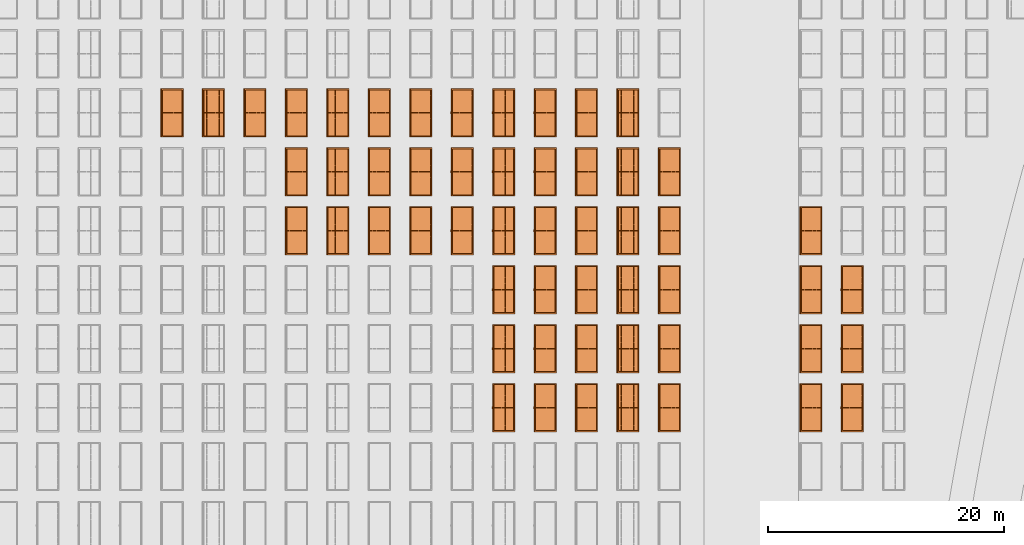
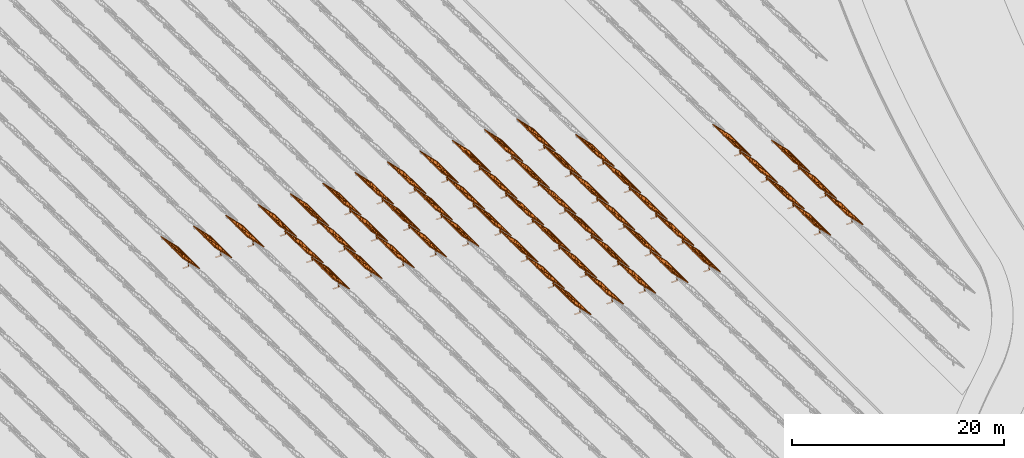
# One storey, part 23 of 39: 54 proxies.
"""IFC2X3 building model written with IfcOpenShell, lengths in millimetres."""

from ifc_helpers import new_model, entity, si_unit, converted_unit, derived_unit, direction, frame, frame_2d, origin, origin_2d_with_axis, place, context, subcontext, project, spatial, polyline, rectangle, outline, extrude, source, transform, mapped, material, material_list, element, save


model = new_model("IFC2X3")

# Units and contexts
model_context = context("Model", 3, precision=1e-06, world=origin(), true_north=direction((2.0, 6.12303176911189e-17, 1.0)))
context_of_model = context(None, 3, precision=1e-06, world=origin(), true_north=direction((2.0, 6.12303176911189e-17, 1.0)))
body_context = subcontext(model_context, "Body", "Model", "MODEL_VIEW")
ifc_project = project(units=[si_unit("LENGTHUNIT", "METRE", prefix="MILLI"), si_unit("AREAUNIT", "SQUARE_METRE", prefix="MILLI"), si_unit("VOLUMEUNIT", "CUBIC_METRE", prefix="MILLI"), converted_unit("PLANEANGLEUNIT", "DEGREE", entity("IfcRatioMeasure", 0.0174532925199433), si_unit("PLANEANGLEUNIT", "RADIAN"), dimensions=[0, 0, 0, 0, 0, 0, 0]), si_unit("MASSUNIT", "GRAM", prefix="KILO"), si_unit("TIMEUNIT", "SECOND"), si_unit("THERMODYNAMICTEMPERATUREUNIT", "KELVIN"), derived_unit("THERMALTRANSMITTANCEUNIT", [(si_unit("MASSUNIT", "GRAM", prefix="KILO"), 1), (si_unit("THERMODYNAMICTEMPERATUREUNIT", "KELVIN"), -1), (si_unit("TIMEUNIT", "SECOND"), -3)]), derived_unit("VOLUMETRICFLOWRATEUNIT", [(si_unit("LENGTHUNIT", "METRE"), 3), (si_unit("TIMEUNIT", "SECOND"), -1)])], contexts=[model_context, context_of_model])

# Site, building, storey
site_placement = place(None, origin())
site = spatial("IfcSite", under=ifc_project, at=site_placement, CompositionType="ELEMENT")
building_placement = place(site_placement, origin())
building = spatial("IfcBuilding", under=site, at=building_placement, CompositionType="ELEMENT")
storey_placement = place(building_placement, frame((0.0, 0.0, 4000.0)))
storey = spatial("IfcBuildingStorey", under=building, at=storey_placement, Name="Level 2", CompositionType="ELEMENT", Elevation=4000.0)

# Proxies
ifc_material_1 = material(Name="Stand-Steel")
ifc_material_2 = material(Name="Aluminium")
ifc_material_3 = material(Name="Glass")
ifc_material_list_1 = material_list([ifc_material_1, ifc_material_2, ifc_material_3])
shared_shape = source(origin(), body_context, "Body", "SweptSolid", [
    extrude(outline(polyline([(-629.526235435404, -220.0), (329.763117717702, -220.0), (329.763117717703, 410.0), (299.763117717703, 410.0), (299.763117717702, -190.0), (-629.526235435404, -190.0), (-629.526235435404, -220.0)])), frame((-190.00003127179, -100.0, 299.763117717707), z_axis=(0.0, 1.0, 0.0), x_axis=(0.0, 0.0, -1.0)), (0.0, 0.0, 1.0), 200.0),
    extrude(rectangle(XDim=20.0000000000001, YDim=200.0, at=frame_2d((0.0, -7.105427357601e-14), x_axis=(0.0, 1.0))), frame((-7.07109908365613, 0.0, 922.21828534124), z_axis=(-0.70710678118654, 0.0, 0.707106781186555), x_axis=(0.0, 1.0, 0.0)), (0.0, 0.0, 1.0), 2600.0),
    extrude(rectangle(XDim=24.9999999999997, YDim=24.9999999999999, at=frame_2d((2.87769807982841e-13, -9.50350909079134e-14), x_axis=(1.0, 0.0))), frame((-1449.56292018118, -1950.0, 2449.57494522722), z_axis=(0.0, 1.0, 0.0), x_axis=(-0.707106781186548, 0.0, -0.707106781186548)), (0.0, 0.0, 1.0), 3900.0),
    extrude(rectangle(XDim=24.9999999999999, YDim=25.0000000000001, at=origin_2d_with_axis()), frame((-1096.0095295879, -1950.0, 2096.02155463395), z_axis=(0.0, 1.0, 0.0), x_axis=(-0.707106781186542, 0.0, -0.707106781186553)), (0.0, 0.0, 1.0), 3900.0),
    extrude(rectangle(XDim=24.9999999999999, YDim=25.0000000000001, at=origin_2d_with_axis()), frame((-742.456138994631, -1950.0, 1742.46816404067), z_axis=(0.0, 1.0, 0.0), x_axis=(-0.707106781186542, 0.0, -0.707106781186553)), (0.0, 0.0, 1.0), 3900.0),
    extrude(rectangle(XDim=25.0, YDim=24.9999999999997, at=frame_2d((-7.19424519957101e-14, 1.19904086659517e-13), x_axis=(1.0, 0.0))), frame((-388.902748401358, -1950.0, 1388.9147734474), z_axis=(0.0, 1.0, 0.0), x_axis=(-0.707106781186545, 0.0, -0.70710678118655)), (0.0, 0.0, 1.0), 3900.0),
    extrude(rectangle(XDim=25.0000000000002, YDim=25.0, at=frame_2d((1.35891298214119e-13, 6.21724893790088e-15), x_axis=(0.0, 1.0))), frame((-35.3553703311048, 1500.0, 1035.35537033109), z_axis=(-0.707106781186544, 0.0, 0.707106781186551), x_axis=(0.0, 1.0, 0.0)), (0.0, 0.0, 1.0), 2440.0),
    extrude(rectangle(XDim=25.0000000000002, YDim=25.0, at=frame_2d((0.0, 1.77635683940025e-15), x_axis=(0.0, 1.0))), frame((-35.3553703311059, 1000.0, 1035.35537033109), z_axis=(-0.707106781186546, 0.0, 0.707106781186549), x_axis=(0.0, 1.0, 0.0)), (0.0, 0.0, 1.0), 2440.0),
    extrude(rectangle(XDim=25.0000000000002, YDim=25.0, at=frame_2d((0.0, 8.43769498715119e-14), x_axis=(0.0, 1.0))), frame((-26.5165355662756, 0.0, 1044.19420509593), z_axis=(-0.707106781186546, 0.0, 0.707106781186549), x_axis=(0.0, -1.0, 0.0)), (0.0, 0.0, 1.0), 2440.0),
    extrude(rectangle(XDim=25.0000000000002, YDim=25.0, at=frame_2d((0.0, 8.88178419700125e-16), x_axis=(0.0, 1.0))), frame((-35.3553703311065, 500.0, 1035.35537033109), z_axis=(-0.707106781186546, 0.0, 0.707106781186549), x_axis=(0.0, 1.0, 0.0)), (0.0, 0.0, 1.0), 2440.0),
    extrude(rectangle(XDim=25.0000000000002, YDim=25.0, at=frame_2d((0.0, 8.88178419700125e-16), x_axis=(0.0, 1.0))), frame((-35.3553703311086, -500.0, 1035.35537033109), z_axis=(-0.707106781186546, 0.0, 0.707106781186549), x_axis=(0.0, 1.0, 0.0)), (0.0, 0.0, 1.0), 2440.0),
    extrude(rectangle(XDim=25.0000000000002, YDim=25.0, at=frame_2d((0.0, 8.88178419700125e-16), x_axis=(0.0, 1.0))), frame((-35.3553703311095, -1000.0, 1035.35537033109), z_axis=(-0.707106781186546, 0.0, 0.707106781186549), x_axis=(0.0, 1.0, 0.0)), (0.0, 0.0, 1.0), 2440.0),
    extrude(rectangle(XDim=25.0000000000002, YDim=25.0, at=frame_2d((1.35891298214119e-13, 1.77635683940025e-15), x_axis=(0.0, 1.0))), frame((-35.3553703311107, -1500.0, 1035.35537033109), z_axis=(-0.707106781186546, 0.0, 0.707106781186549), x_axis=(0.0, 1.0, 0.0)), (0.0, 0.0, 1.0), 2440.0),
    extrude(rectangle(XDim=2400.0, YDim=11.9999999999994, at=frame_2d((-1.13686837721616e-13, 2.02948768901479e-13), x_axis=(1.0, 0.0))), frame((-883.883507754966, -1950.0, 1883.88350775495), z_axis=(0.0, 1.0, 0.0), x_axis=(0.707106781186546, 0.0, -0.707106781186549)), (0.0, 0.0, 1.0), 3900.0),
    extrude(outline(polyline([(-2050.0, -1300.0), (2050.0, -1300.0), (2050.0, 1300.0), (-2050.0, 1300.0), (-2050.0, -1300.0)]), holes=[polyline([(1950.0, -1200.0), (-1950.0, -1200.0), (-1950.0, 1200.0), (1950.0, 1200.0), (1950.0, -1200.0)])]), frame((-919.238846814293, 0.0, 1848.52816869563), z_axis=(0.707106781186554, 0.0, 0.707106781186541), x_axis=(0.0, 1.0, 0.0)), (0.0, 0.0, 1.0), 99.9999999999898),
])
proxy_1_placement = place(storey_placement, frame((-144385.32831183, 500144.680552409, 30.0)))
element("IfcBuildingElementProxy", 1, at=proxy_1_placement, inside=storey, material=ifc_material_list_1, Name="Solar Panel_4000X2500:Solar Panel_4000X2500", ObjectType="Solar Panel_4000X2500", CompositionType="ELEMENT", context=body_context, shape_type="MappedRepresentation", body=[
    mapped(shared_shape, transform((0.0, 0.0, 0.0), scale=1.0)),
])
ifc_material_list_2 = material_list([ifc_material_1, ifc_material_2, ifc_material_3])
proxy_2_placement = place(storey_placement, frame((-144385.32831183, 505144.680552409, 30.0)))
element("IfcBuildingElementProxy", 2, at=proxy_2_placement, inside=storey, material=ifc_material_list_2, Name="Solar Panel_4000X2500:Solar Panel_4000X2500", ObjectType="Solar Panel_4000X2500", CompositionType="ELEMENT", context=body_context, shape_type="MappedRepresentation", body=[
    mapped(shared_shape, transform((0.0, 0.0, 0.0), scale=1.0)),
])
ifc_material_list_3 = material_list([ifc_material_1, ifc_material_2, ifc_material_3])
proxy_3_placement = place(storey_placement, frame((-144385.32831183, 510144.680552409, 30.0)))
element("IfcBuildingElementProxy", 3, at=proxy_3_placement, inside=storey, material=ifc_material_list_3, Name="Solar Panel_4000X2500:Solar Panel_4000X2500", ObjectType="Solar Panel_4000X2500", CompositionType="ELEMENT", context=body_context, shape_type="MappedRepresentation", body=[
    mapped(shared_shape, transform((0.0, 0.0, 0.0), scale=1.0)),
])
ifc_material_list_4 = material_list([ifc_material_1, ifc_material_2, ifc_material_3])
proxy_4_placement = place(storey_placement, frame((-147885.32831183, 500144.680552409, 30.0)))
element("IfcBuildingElementProxy", 4, at=proxy_4_placement, inside=storey, material=ifc_material_list_4, Name="Solar Panel_4000X2500:Solar Panel_4000X2500", ObjectType="Solar Panel_4000X2500", CompositionType="ELEMENT", context=body_context, shape_type="MappedRepresentation", body=[
    mapped(shared_shape, transform((0.0, 0.0, 0.0), scale=1.0)),
])
ifc_material_list_5 = material_list([ifc_material_1, ifc_material_2, ifc_material_3])
proxy_5_placement = place(storey_placement, frame((-147885.32831183, 505144.680552409, 30.0)))
element("IfcBuildingElementProxy", 5, at=proxy_5_placement, inside=storey, material=ifc_material_list_5, Name="Solar Panel_4000X2500:Solar Panel_4000X2500", ObjectType="Solar Panel_4000X2500", CompositionType="ELEMENT", context=body_context, shape_type="MappedRepresentation", body=[
    mapped(shared_shape, transform((0.0, 0.0, 0.0), scale=1.0)),
])
ifc_material_list_6 = material_list([ifc_material_1, ifc_material_2, ifc_material_3])
proxy_6_placement = place(storey_placement, frame((-147885.32831183, 510144.680552409, 30.0)))
element("IfcBuildingElementProxy", 6, at=proxy_6_placement, inside=storey, material=ifc_material_list_6, Name="Solar Panel_4000X2500:Solar Panel_4000X2500", ObjectType="Solar Panel_4000X2500", CompositionType="ELEMENT", context=body_context, shape_type="MappedRepresentation", body=[
    mapped(shared_shape, transform((0.0, 0.0, 0.0), scale=1.0)),
])
ifc_material_list_7 = material_list([ifc_material_1, ifc_material_2, ifc_material_3])
proxy_7_placement = place(storey_placement, frame((-147885.32831183, 515144.680552409, 30.0)))
element("IfcBuildingElementProxy", 7, at=proxy_7_placement, inside=storey, material=ifc_material_list_7, Name="Solar Panel_4000X2500:Solar Panel_4000X2500", ObjectType="Solar Panel_4000X2500", CompositionType="ELEMENT", context=body_context, shape_type="MappedRepresentation", body=[
    mapped(shared_shape, transform((0.0, 0.0, 0.0), scale=1.0)),
])
ifc_material_list_8 = material_list([ifc_material_1, ifc_material_2, ifc_material_3])
proxy_8_placement = place(storey_placement, frame((-159885.32831183, 500144.680552409, 30.0)))
element("IfcBuildingElementProxy", 8, at=proxy_8_placement, inside=storey, material=ifc_material_list_8, Name="Solar Panel_4000X2500:Solar Panel_4000X2500", ObjectType="Solar Panel_4000X2500", CompositionType="ELEMENT", context=body_context, shape_type="MappedRepresentation", body=[
    mapped(shared_shape, transform((0.0, 0.0, 0.0), scale=1.0)),
])
ifc_material_list_9 = material_list([ifc_material_1, ifc_material_2, ifc_material_3])
proxy_9_placement = place(storey_placement, frame((-159885.32831183, 505144.680552409, 30.0)))
element("IfcBuildingElementProxy", 9, at=proxy_9_placement, inside=storey, material=ifc_material_list_9, Name="Solar Panel_4000X2500:Solar Panel_4000X2500", ObjectType="Solar Panel_4000X2500", CompositionType="ELEMENT", context=body_context, shape_type="MappedRepresentation", body=[
    mapped(shared_shape, transform((0.0, 0.0, 0.0), scale=1.0)),
])
ifc_material_list_10 = material_list([ifc_material_1, ifc_material_2, ifc_material_3])
proxy_10_placement = place(storey_placement, frame((-159885.32831183, 510144.680552409, 30.0)))
element("IfcBuildingElementProxy", 10, at=proxy_10_placement, inside=storey, material=ifc_material_list_10, Name="Solar Panel_4000X2500:Solar Panel_4000X2500", ObjectType="Solar Panel_4000X2500", CompositionType="ELEMENT", context=body_context, shape_type="MappedRepresentation", body=[
    mapped(shared_shape, transform((0.0, 0.0, 0.0), scale=1.0)),
])
ifc_material_list_11 = material_list([ifc_material_1, ifc_material_2, ifc_material_3])
proxy_11_placement = place(storey_placement, frame((-159885.32831183, 515144.680552409, 30.0)))
element("IfcBuildingElementProxy", 11, at=proxy_11_placement, inside=storey, material=ifc_material_list_11, Name="Solar Panel_4000X2500:Solar Panel_4000X2500", ObjectType="Solar Panel_4000X2500", CompositionType="ELEMENT", context=body_context, shape_type="MappedRepresentation", body=[
    mapped(shared_shape, transform((0.0, 0.0, 0.0), scale=1.0)),
])
ifc_material_list_12 = material_list([ifc_material_1, ifc_material_2, ifc_material_3])
proxy_12_placement = place(storey_placement, frame((-159885.32831183, 520144.680552409, 30.0)))
element("IfcBuildingElementProxy", 12, at=proxy_12_placement, inside=storey, material=ifc_material_list_12, Name="Solar Panel_4000X2500:Solar Panel_4000X2500", ObjectType="Solar Panel_4000X2500", CompositionType="ELEMENT", context=body_context, shape_type="MappedRepresentation", body=[
    mapped(shared_shape, transform((0.0, 0.0, 0.0), scale=1.0)),
])
ifc_material_list_13 = material_list([ifc_material_1, ifc_material_2, ifc_material_3])
proxy_13_placement = place(storey_placement, frame((-163400.32831183, 500144.680552409, 30.0)))
element("IfcBuildingElementProxy", 13, at=proxy_13_placement, inside=storey, material=ifc_material_list_13, Name="Solar Panel_4000X2500:Solar Panel_4000X2500", ObjectType="Solar Panel_4000X2500", CompositionType="ELEMENT", context=body_context, shape_type="MappedRepresentation", body=[
    mapped(shared_shape, transform((0.0, 0.0, 0.0), scale=1.0)),
])
ifc_material_list_14 = material_list([ifc_material_1, ifc_material_2, ifc_material_3])
proxy_14_placement = place(storey_placement, frame((-163400.32831183, 505144.680552409, 30.0)))
element("IfcBuildingElementProxy", 14, at=proxy_14_placement, inside=storey, material=ifc_material_list_14, Name="Solar Panel_4000X2500:Solar Panel_4000X2500", ObjectType="Solar Panel_4000X2500", CompositionType="ELEMENT", context=body_context, shape_type="MappedRepresentation", body=[
    mapped(shared_shape, transform((0.0, 0.0, 0.0), scale=1.0)),
])
ifc_material_list_15 = material_list([ifc_material_1, ifc_material_2, ifc_material_3])
proxy_15_placement = place(storey_placement, frame((-163400.32831183, 510144.680552409, 30.0)))
element("IfcBuildingElementProxy", 15, at=proxy_15_placement, inside=storey, material=ifc_material_list_15, Name="Solar Panel_4000X2500:Solar Panel_4000X2500", ObjectType="Solar Panel_4000X2500", CompositionType="ELEMENT", context=body_context, shape_type="MappedRepresentation", body=[
    mapped(shared_shape, transform((0.0, 0.0, 0.0), scale=1.0)),
])
ifc_material_list_16 = material_list([ifc_material_1, ifc_material_2, ifc_material_3])
proxy_16_placement = place(storey_placement, frame((-163400.32831183, 515144.680552409, 30.0)))
element("IfcBuildingElementProxy", 16, at=proxy_16_placement, inside=storey, material=ifc_material_list_16, Name="Solar Panel_4000X2500:Solar Panel_4000X2500", ObjectType="Solar Panel_4000X2500", CompositionType="ELEMENT", context=body_context, shape_type="MappedRepresentation", body=[
    mapped(shared_shape, transform((0.0, 0.0, 0.0), scale=1.0)),
])
ifc_material_list_17 = material_list([ifc_material_1, ifc_material_2, ifc_material_3])
proxy_17_placement = place(storey_placement, frame((-163400.32831183, 520144.680552409, 30.0)))
element("IfcBuildingElementProxy", 17, at=proxy_17_placement, inside=storey, material=ifc_material_list_17, Name="Solar Panel_4000X2500:Solar Panel_4000X2500", ObjectType="Solar Panel_4000X2500", CompositionType="ELEMENT", context=body_context, shape_type="MappedRepresentation", body=[
    mapped(shared_shape, transform((0.0, 0.0, 0.0), scale=1.0)),
])
ifc_material_list_18 = material_list([ifc_material_1, ifc_material_2, ifc_material_3])
proxy_18_placement = place(storey_placement, frame((-163400.32831183, 525144.680552409, 30.0)))
element("IfcBuildingElementProxy", 18, at=proxy_18_placement, inside=storey, material=ifc_material_list_18, Name="Solar Panel_4000X2500:Solar Panel_4000X2500", ObjectType="Solar Panel_4000X2500", CompositionType="ELEMENT", context=body_context, shape_type="MappedRepresentation", body=[
    mapped(shared_shape, transform((0.0, 0.0, 0.0), scale=1.0)),
])
ifc_material_list_19 = material_list([ifc_material_1, ifc_material_2, ifc_material_3])
proxy_19_placement = place(storey_placement, frame((-166915.32831183, 500144.680552409, 30.0)))
element("IfcBuildingElementProxy", 19, at=proxy_19_placement, inside=storey, material=ifc_material_list_19, Name="Solar Panel_4000X2500:Solar Panel_4000X2500", ObjectType="Solar Panel_4000X2500", CompositionType="ELEMENT", context=body_context, shape_type="MappedRepresentation", body=[
    mapped(shared_shape, transform((0.0, 0.0, 0.0), scale=1.0)),
])
ifc_material_list_20 = material_list([ifc_material_1, ifc_material_2, ifc_material_3])
proxy_20_placement = place(storey_placement, frame((-166915.32831183, 505144.680552409, 30.0)))
element("IfcBuildingElementProxy", 20, at=proxy_20_placement, inside=storey, material=ifc_material_list_20, Name="Solar Panel_4000X2500:Solar Panel_4000X2500", ObjectType="Solar Panel_4000X2500", CompositionType="ELEMENT", context=body_context, shape_type="MappedRepresentation", body=[
    mapped(shared_shape, transform((0.0, 0.0, 0.0), scale=1.0)),
])
ifc_material_list_21 = material_list([ifc_material_1, ifc_material_2, ifc_material_3])
proxy_21_placement = place(storey_placement, frame((-166915.32831183, 510144.680552409, 30.0)))
element("IfcBuildingElementProxy", 21, at=proxy_21_placement, inside=storey, material=ifc_material_list_21, Name="Solar Panel_4000X2500:Solar Panel_4000X2500", ObjectType="Solar Panel_4000X2500", CompositionType="ELEMENT", context=body_context, shape_type="MappedRepresentation", body=[
    mapped(shared_shape, transform((0.0, 0.0, 0.0), scale=1.0)),
])
ifc_material_list_22 = material_list([ifc_material_1, ifc_material_2, ifc_material_3])
proxy_22_placement = place(storey_placement, frame((-166915.32831183, 515144.680552409, 30.0)))
element("IfcBuildingElementProxy", 22, at=proxy_22_placement, inside=storey, material=ifc_material_list_22, Name="Solar Panel_4000X2500:Solar Panel_4000X2500", ObjectType="Solar Panel_4000X2500", CompositionType="ELEMENT", context=body_context, shape_type="MappedRepresentation", body=[
    mapped(shared_shape, transform((0.0, 0.0, 0.0), scale=1.0)),
])
ifc_material_list_23 = material_list([ifc_material_1, ifc_material_2, ifc_material_3])
proxy_23_placement = place(storey_placement, frame((-166915.32831183, 520144.680552409, 30.0)))
element("IfcBuildingElementProxy", 23, at=proxy_23_placement, inside=storey, material=ifc_material_list_23, Name="Solar Panel_4000X2500:Solar Panel_4000X2500", ObjectType="Solar Panel_4000X2500", CompositionType="ELEMENT", context=body_context, shape_type="MappedRepresentation", body=[
    mapped(shared_shape, transform((0.0, 0.0, 0.0), scale=1.0)),
])
ifc_material_list_24 = material_list([ifc_material_1, ifc_material_2, ifc_material_3])
proxy_24_placement = place(storey_placement, frame((-166915.32831183, 525144.680552409, 30.0)))
element("IfcBuildingElementProxy", 24, at=proxy_24_placement, inside=storey, material=ifc_material_list_24, Name="Solar Panel_4000X2500:Solar Panel_4000X2500", ObjectType="Solar Panel_4000X2500", CompositionType="ELEMENT", context=body_context, shape_type="MappedRepresentation", body=[
    mapped(shared_shape, transform((0.0, 0.0, 0.0), scale=1.0)),
])
ifc_material_list_25 = material_list([ifc_material_1, ifc_material_2, ifc_material_3])
proxy_25_placement = place(storey_placement, frame((-170430.32831183, 500144.680552409, 30.0)))
element("IfcBuildingElementProxy", 25, at=proxy_25_placement, inside=storey, material=ifc_material_list_25, Name="Solar Panel_4000X2500:Solar Panel_4000X2500", ObjectType="Solar Panel_4000X2500", CompositionType="ELEMENT", context=body_context, shape_type="MappedRepresentation", body=[
    mapped(shared_shape, transform((0.0, 0.0, 0.0), scale=1.0)),
])
ifc_material_list_26 = material_list([ifc_material_1, ifc_material_2, ifc_material_3])
proxy_26_placement = place(storey_placement, frame((-170430.32831183, 505144.680552409, 30.0)))
element("IfcBuildingElementProxy", 26, at=proxy_26_placement, inside=storey, material=ifc_material_list_26, Name="Solar Panel_4000X2500:Solar Panel_4000X2500", ObjectType="Solar Panel_4000X2500", CompositionType="ELEMENT", context=body_context, shape_type="MappedRepresentation", body=[
    mapped(shared_shape, transform((0.0, 0.0, 0.0), scale=1.0)),
])
ifc_material_list_27 = material_list([ifc_material_1, ifc_material_2, ifc_material_3])
proxy_27_placement = place(storey_placement, frame((-170430.32831183, 510144.680552409, 30.0)))
element("IfcBuildingElementProxy", 27, at=proxy_27_placement, inside=storey, material=ifc_material_list_27, Name="Solar Panel_4000X2500:Solar Panel_4000X2500", ObjectType="Solar Panel_4000X2500", CompositionType="ELEMENT", context=body_context, shape_type="MappedRepresentation", body=[
    mapped(shared_shape, transform((0.0, 0.0, 0.0), scale=1.0)),
])
ifc_material_list_28 = material_list([ifc_material_1, ifc_material_2, ifc_material_3])
proxy_28_placement = place(storey_placement, frame((-170430.32831183, 515144.680552409, 30.0)))
element("IfcBuildingElementProxy", 28, at=proxy_28_placement, inside=storey, material=ifc_material_list_28, Name="Solar Panel_4000X2500:Solar Panel_4000X2500", ObjectType="Solar Panel_4000X2500", CompositionType="ELEMENT", context=body_context, shape_type="MappedRepresentation", body=[
    mapped(shared_shape, transform((0.0, 0.0, 0.0), scale=1.0)),
])
ifc_material_list_29 = material_list([ifc_material_1, ifc_material_2, ifc_material_3])
proxy_29_placement = place(storey_placement, frame((-170430.32831183, 520144.680552409, 30.0)))
element("IfcBuildingElementProxy", 29, at=proxy_29_placement, inside=storey, material=ifc_material_list_29, Name="Solar Panel_4000X2500:Solar Panel_4000X2500", ObjectType="Solar Panel_4000X2500", CompositionType="ELEMENT", context=body_context, shape_type="MappedRepresentation", body=[
    mapped(shared_shape, transform((0.0, 0.0, 0.0), scale=1.0)),
])
ifc_material_list_30 = material_list([ifc_material_1, ifc_material_2, ifc_material_3])
proxy_30_placement = place(storey_placement, frame((-170430.32831183, 525144.680552409, 30.0)))
element("IfcBuildingElementProxy", 30, at=proxy_30_placement, inside=storey, material=ifc_material_list_30, Name="Solar Panel_4000X2500:Solar Panel_4000X2500", ObjectType="Solar Panel_4000X2500", CompositionType="ELEMENT", context=body_context, shape_type="MappedRepresentation", body=[
    mapped(shared_shape, transform((0.0, 0.0, 0.0), scale=1.0)),
])
ifc_material_list_31 = material_list([ifc_material_1, ifc_material_2, ifc_material_3])
proxy_31_placement = place(storey_placement, frame((-173945.32831183, 500144.680552409, 30.0)))
element("IfcBuildingElementProxy", 31, at=proxy_31_placement, inside=storey, material=ifc_material_list_31, Name="Solar Panel_4000X2500:Solar Panel_4000X2500", ObjectType="Solar Panel_4000X2500", CompositionType="ELEMENT", context=body_context, shape_type="MappedRepresentation", body=[
    mapped(shared_shape, transform((0.0, 0.0, 0.0), scale=1.0)),
])
ifc_material_list_32 = material_list([ifc_material_1, ifc_material_2, ifc_material_3])
proxy_32_placement = place(storey_placement, frame((-173945.32831183, 505144.680552409, 30.0)))
element("IfcBuildingElementProxy", 32, at=proxy_32_placement, inside=storey, material=ifc_material_list_32, Name="Solar Panel_4000X2500:Solar Panel_4000X2500", ObjectType="Solar Panel_4000X2500", CompositionType="ELEMENT", context=body_context, shape_type="MappedRepresentation", body=[
    mapped(shared_shape, transform((0.0, 0.0, 0.0), scale=1.0)),
])
ifc_material_list_33 = material_list([ifc_material_1, ifc_material_2, ifc_material_3])
proxy_33_placement = place(storey_placement, frame((-173945.32831183, 510144.680552409, 30.0)))
element("IfcBuildingElementProxy", 33, at=proxy_33_placement, inside=storey, material=ifc_material_list_33, Name="Solar Panel_4000X2500:Solar Panel_4000X2500", ObjectType="Solar Panel_4000X2500", CompositionType="ELEMENT", context=body_context, shape_type="MappedRepresentation", body=[
    mapped(shared_shape, transform((0.0, 0.0, 0.0), scale=1.0)),
])
ifc_material_list_34 = material_list([ifc_material_1, ifc_material_2, ifc_material_3])
proxy_34_placement = place(storey_placement, frame((-173945.32831183, 515144.680552409, 30.0)))
element("IfcBuildingElementProxy", 34, at=proxy_34_placement, inside=storey, material=ifc_material_list_34, Name="Solar Panel_4000X2500:Solar Panel_4000X2500", ObjectType="Solar Panel_4000X2500", CompositionType="ELEMENT", context=body_context, shape_type="MappedRepresentation", body=[
    mapped(shared_shape, transform((0.0, 0.0, 0.0), scale=1.0)),
])
ifc_material_list_35 = material_list([ifc_material_1, ifc_material_2, ifc_material_3])
proxy_35_placement = place(storey_placement, frame((-173945.32831183, 520144.680552409, 30.0)))
element("IfcBuildingElementProxy", 35, at=proxy_35_placement, inside=storey, material=ifc_material_list_35, Name="Solar Panel_4000X2500:Solar Panel_4000X2500", ObjectType="Solar Panel_4000X2500", CompositionType="ELEMENT", context=body_context, shape_type="MappedRepresentation", body=[
    mapped(shared_shape, transform((0.0, 0.0, 0.0), scale=1.0)),
])
ifc_material_list_36 = material_list([ifc_material_1, ifc_material_2, ifc_material_3])
proxy_36_placement = place(storey_placement, frame((-173945.32831183, 525144.680552409, 30.0)))
element("IfcBuildingElementProxy", 36, at=proxy_36_placement, inside=storey, material=ifc_material_list_36, Name="Solar Panel_4000X2500:Solar Panel_4000X2500", ObjectType="Solar Panel_4000X2500", CompositionType="ELEMENT", context=body_context, shape_type="MappedRepresentation", body=[
    mapped(shared_shape, transform((0.0, 0.0, 0.0), scale=1.0)),
])
ifc_material_list_37 = material_list([ifc_material_1, ifc_material_2, ifc_material_3])
proxy_37_placement = place(storey_placement, frame((-177460.32831183, 515144.680552409, 30.0)))
element("IfcBuildingElementProxy", 37, at=proxy_37_placement, inside=storey, material=ifc_material_list_37, Name="Solar Panel_4000X2500:Solar Panel_4000X2500", ObjectType="Solar Panel_4000X2500", CompositionType="ELEMENT", context=body_context, shape_type="MappedRepresentation", body=[
    mapped(shared_shape, transform((0.0, 0.0, 0.0), scale=1.0)),
])
ifc_material_list_38 = material_list([ifc_material_1, ifc_material_2, ifc_material_3])
proxy_38_placement = place(storey_placement, frame((-177460.32831183, 520144.680552409, 30.0)))
element("IfcBuildingElementProxy", 38, at=proxy_38_placement, inside=storey, material=ifc_material_list_38, Name="Solar Panel_4000X2500:Solar Panel_4000X2500", ObjectType="Solar Panel_4000X2500", CompositionType="ELEMENT", context=body_context, shape_type="MappedRepresentation", body=[
    mapped(shared_shape, transform((0.0, 0.0, 0.0), scale=1.0)),
])
ifc_material_list_39 = material_list([ifc_material_1, ifc_material_2, ifc_material_3])
proxy_39_placement = place(storey_placement, frame((-177460.32831183, 525144.680552409, 30.0)))
element("IfcBuildingElementProxy", 39, at=proxy_39_placement, inside=storey, material=ifc_material_list_39, Name="Solar Panel_4000X2500:Solar Panel_4000X2500", ObjectType="Solar Panel_4000X2500", CompositionType="ELEMENT", context=body_context, shape_type="MappedRepresentation", body=[
    mapped(shared_shape, transform((0.0, 0.0, 0.0), scale=1.0)),
])
ifc_material_list_40 = material_list([ifc_material_1, ifc_material_2, ifc_material_3])
proxy_40_placement = place(storey_placement, frame((-180975.32831183, 515144.680552409, 30.0)))
element("IfcBuildingElementProxy", 40, at=proxy_40_placement, inside=storey, material=ifc_material_list_40, Name="Solar Panel_4000X2500:Solar Panel_4000X2500", ObjectType="Solar Panel_4000X2500", CompositionType="ELEMENT", context=body_context, shape_type="MappedRepresentation", body=[
    mapped(shared_shape, transform((0.0, 0.0, 0.0), scale=1.0)),
])
ifc_material_list_41 = material_list([ifc_material_1, ifc_material_2, ifc_material_3])
proxy_41_placement = place(storey_placement, frame((-180975.32831183, 520144.680552409, 30.0)))
element("IfcBuildingElementProxy", 41, at=proxy_41_placement, inside=storey, material=ifc_material_list_41, Name="Solar Panel_4000X2500:Solar Panel_4000X2500", ObjectType="Solar Panel_4000X2500", CompositionType="ELEMENT", context=body_context, shape_type="MappedRepresentation", body=[
    mapped(shared_shape, transform((0.0, 0.0, 0.0), scale=1.0)),
])
ifc_material_list_42 = material_list([ifc_material_1, ifc_material_2, ifc_material_3])
proxy_42_placement = place(storey_placement, frame((-180975.32831183, 525144.680552409, 30.0)))
element("IfcBuildingElementProxy", 42, at=proxy_42_placement, inside=storey, material=ifc_material_list_42, Name="Solar Panel_4000X2500:Solar Panel_4000X2500", ObjectType="Solar Panel_4000X2500", CompositionType="ELEMENT", context=body_context, shape_type="MappedRepresentation", body=[
    mapped(shared_shape, transform((0.0, 0.0, 0.0), scale=1.0)),
])
ifc_material_list_43 = material_list([ifc_material_1, ifc_material_2, ifc_material_3])
proxy_43_placement = place(storey_placement, frame((-184490.32831183, 515144.680552409, 30.0)))
element("IfcBuildingElementProxy", 43, at=proxy_43_placement, inside=storey, material=ifc_material_list_43, Name="Solar Panel_4000X2500:Solar Panel_4000X2500", ObjectType="Solar Panel_4000X2500", CompositionType="ELEMENT", context=body_context, shape_type="MappedRepresentation", body=[
    mapped(shared_shape, transform((0.0, 0.0, 0.0), scale=1.0)),
])
ifc_material_list_44 = material_list([ifc_material_1, ifc_material_2, ifc_material_3])
proxy_44_placement = place(storey_placement, frame((-184490.32831183, 520144.680552409, 30.0)))
element("IfcBuildingElementProxy", 44, at=proxy_44_placement, inside=storey, material=ifc_material_list_44, Name="Solar Panel_4000X2500:Solar Panel_4000X2500", ObjectType="Solar Panel_4000X2500", CompositionType="ELEMENT", context=body_context, shape_type="MappedRepresentation", body=[
    mapped(shared_shape, transform((0.0, 0.0, 0.0), scale=1.0)),
])
ifc_material_list_45 = material_list([ifc_material_1, ifc_material_2, ifc_material_3])
proxy_45_placement = place(storey_placement, frame((-184490.32831183, 525144.680552409, 30.0)))
element("IfcBuildingElementProxy", 45, at=proxy_45_placement, inside=storey, material=ifc_material_list_45, Name="Solar Panel_4000X2500:Solar Panel_4000X2500", ObjectType="Solar Panel_4000X2500", CompositionType="ELEMENT", context=body_context, shape_type="MappedRepresentation", body=[
    mapped(shared_shape, transform((0.0, 0.0, 0.0), scale=1.0)),
])
ifc_material_list_46 = material_list([ifc_material_1, ifc_material_2, ifc_material_3])
proxy_46_placement = place(storey_placement, frame((-188005.32831183, 515144.680552409, 30.0)))
element("IfcBuildingElementProxy", 46, at=proxy_46_placement, inside=storey, material=ifc_material_list_46, Name="Solar Panel_4000X2500:Solar Panel_4000X2500", ObjectType="Solar Panel_4000X2500", CompositionType="ELEMENT", context=body_context, shape_type="MappedRepresentation", body=[
    mapped(shared_shape, transform((0.0, 0.0, 0.0), scale=1.0)),
])
ifc_material_list_47 = material_list([ifc_material_1, ifc_material_2, ifc_material_3])
proxy_47_placement = place(storey_placement, frame((-188005.32831183, 520144.680552409, 30.0)))
element("IfcBuildingElementProxy", 47, at=proxy_47_placement, inside=storey, material=ifc_material_list_47, Name="Solar Panel_4000X2500:Solar Panel_4000X2500", ObjectType="Solar Panel_4000X2500", CompositionType="ELEMENT", context=body_context, shape_type="MappedRepresentation", body=[
    mapped(shared_shape, transform((0.0, 0.0, 0.0), scale=1.0)),
])
ifc_material_list_48 = material_list([ifc_material_1, ifc_material_2, ifc_material_3])
proxy_48_placement = place(storey_placement, frame((-188005.32831183, 525144.680552409, 30.0)))
element("IfcBuildingElementProxy", 48, at=proxy_48_placement, inside=storey, material=ifc_material_list_48, Name="Solar Panel_4000X2500:Solar Panel_4000X2500", ObjectType="Solar Panel_4000X2500", CompositionType="ELEMENT", context=body_context, shape_type="MappedRepresentation", body=[
    mapped(shared_shape, transform((0.0, 0.0, 0.0), scale=1.0)),
])
ifc_material_list_49 = material_list([ifc_material_1, ifc_material_2, ifc_material_3])
proxy_49_placement = place(storey_placement, frame((-191520.32831183, 515144.680552409, 30.0)))
element("IfcBuildingElementProxy", 49, at=proxy_49_placement, inside=storey, material=ifc_material_list_49, Name="Solar Panel_4000X2500:Solar Panel_4000X2500", ObjectType="Solar Panel_4000X2500", CompositionType="ELEMENT", context=body_context, shape_type="MappedRepresentation", body=[
    mapped(shared_shape, transform((0.0, 0.0, 0.0), scale=1.0)),
])
ifc_material_list_50 = material_list([ifc_material_1, ifc_material_2, ifc_material_3])
proxy_50_placement = place(storey_placement, frame((-191520.32831183, 520144.680552409, 30.0)))
element("IfcBuildingElementProxy", 50, at=proxy_50_placement, inside=storey, material=ifc_material_list_50, Name="Solar Panel_4000X2500:Solar Panel_4000X2500", ObjectType="Solar Panel_4000X2500", CompositionType="ELEMENT", context=body_context, shape_type="MappedRepresentation", body=[
    mapped(shared_shape, transform((0.0, 0.0, 0.0), scale=1.0)),
])
ifc_material_list_51 = material_list([ifc_material_1, ifc_material_2, ifc_material_3])
proxy_51_placement = place(storey_placement, frame((-191520.32831183, 525144.680552409, 30.0)))
element("IfcBuildingElementProxy", 51, at=proxy_51_placement, inside=storey, material=ifc_material_list_51, Name="Solar Panel_4000X2500:Solar Panel_4000X2500", ObjectType="Solar Panel_4000X2500", CompositionType="ELEMENT", context=body_context, shape_type="MappedRepresentation", body=[
    mapped(shared_shape, transform((0.0, 0.0, 0.0), scale=1.0)),
])
ifc_material_list_52 = material_list([ifc_material_1, ifc_material_2, ifc_material_3])
proxy_52_placement = place(storey_placement, frame((-195035.32831183, 525144.680552409, 30.0)))
element("IfcBuildingElementProxy", 52, at=proxy_52_placement, inside=storey, material=ifc_material_list_52, Name="Solar Panel_4000X2500:Solar Panel_4000X2500", ObjectType="Solar Panel_4000X2500", CompositionType="ELEMENT", context=body_context, shape_type="MappedRepresentation", body=[
    mapped(shared_shape, transform((0.0, 0.0, 0.0), scale=1.0)),
])
ifc_material_list_53 = material_list([ifc_material_1, ifc_material_2, ifc_material_3])
proxy_53_placement = place(storey_placement, frame((-198550.32831183, 525144.680552409, 30.0)))
element("IfcBuildingElementProxy", 53, at=proxy_53_placement, inside=storey, material=ifc_material_list_53, Name="Solar Panel_4000X2500:Solar Panel_4000X2500", ObjectType="Solar Panel_4000X2500", CompositionType="ELEMENT", context=body_context, shape_type="MappedRepresentation", body=[
    mapped(shared_shape, transform((0.0, 0.0, 0.0), scale=1.0)),
])
ifc_material_list_54 = material_list([ifc_material_1, ifc_material_2, ifc_material_3])
proxy_54_placement = place(storey_placement, frame((-202065.32831183, 525144.680552409, 30.0)))
element("IfcBuildingElementProxy", 54, at=proxy_54_placement, inside=storey, material=ifc_material_list_54, Name="Solar Panel_4000X2500:Solar Panel_4000X2500", ObjectType="Solar Panel_4000X2500", CompositionType="ELEMENT", context=body_context, shape_type="MappedRepresentation", body=[
    mapped(shared_shape, transform((0.0, 0.0, 0.0), scale=1.0)),
])

save(model, "model.ifc")
